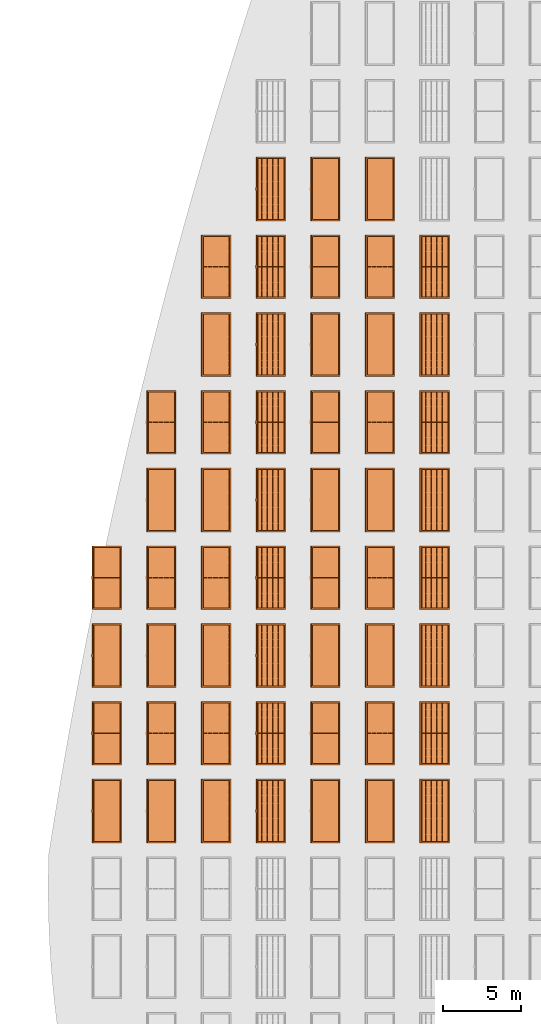
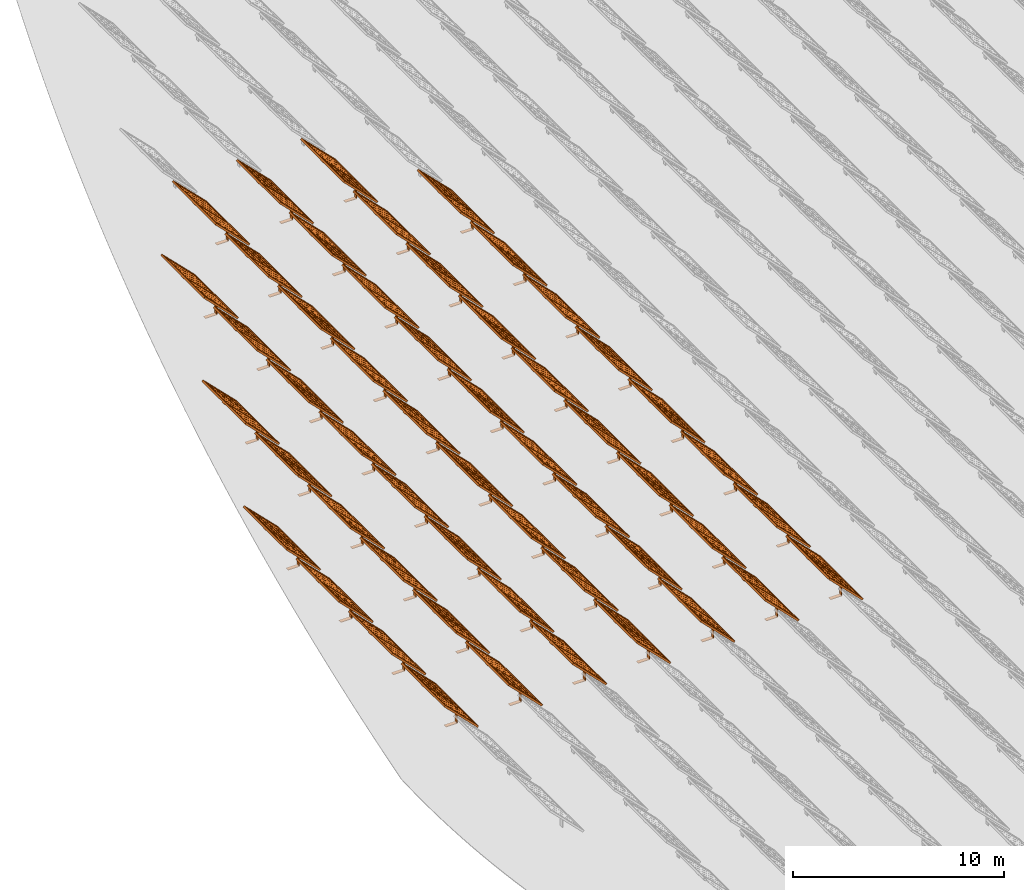
# One storey, part 21 of 39: 53 proxies.
"""IFC2X3 building model written with IfcOpenShell, lengths in millimetres."""

from ifc_helpers import new_model, entity, si_unit, converted_unit, derived_unit, direction, frame, frame_2d, origin, origin_2d_with_axis, place, context, subcontext, project, spatial, polyline, rectangle, outline, extrude, source, transform, mapped, material, material_list, element, save


model = new_model("IFC2X3")

# Units and contexts
model_context = context("Model", 3, precision=1e-06, world=origin(), true_north=direction((2.0, 6.12303176911189e-17, 1.0)))
context_of_model = context(None, 3, precision=1e-06, world=origin(), true_north=direction((2.0, 6.12303176911189e-17, 1.0)))
body_context = subcontext(model_context, "Body", "Model", "MODEL_VIEW")
ifc_project = project(units=[si_unit("LENGTHUNIT", "METRE", prefix="MILLI"), si_unit("AREAUNIT", "SQUARE_METRE", prefix="MILLI"), si_unit("VOLUMEUNIT", "CUBIC_METRE", prefix="MILLI"), converted_unit("PLANEANGLEUNIT", "DEGREE", entity("IfcRatioMeasure", 0.0174532925199433), si_unit("PLANEANGLEUNIT", "RADIAN"), dimensions=[0, 0, 0, 0, 0, 0, 0]), si_unit("MASSUNIT", "GRAM", prefix="KILO"), si_unit("TIMEUNIT", "SECOND"), si_unit("THERMODYNAMICTEMPERATUREUNIT", "KELVIN"), derived_unit("THERMALTRANSMITTANCEUNIT", [(si_unit("MASSUNIT", "GRAM", prefix="KILO"), 1), (si_unit("THERMODYNAMICTEMPERATUREUNIT", "KELVIN"), -1), (si_unit("TIMEUNIT", "SECOND"), -3)]), derived_unit("VOLUMETRICFLOWRATEUNIT", [(si_unit("LENGTHUNIT", "METRE"), 3), (si_unit("TIMEUNIT", "SECOND"), -1)])], contexts=[model_context, context_of_model])

# Site, building, storey
site_placement = place(None, origin())
site = spatial("IfcSite", under=ifc_project, at=site_placement, CompositionType="ELEMENT")
building_placement = place(site_placement, origin())
building = spatial("IfcBuilding", under=site, at=building_placement, CompositionType="ELEMENT")
storey_placement = place(building_placement, frame((0.0, 0.0, 4000.0)))
storey = spatial("IfcBuildingStorey", under=building, at=storey_placement, Name="Level 2", CompositionType="ELEMENT", Elevation=4000.0)

# Proxies
ifc_material_1 = material(Name="Stand-Steel")
ifc_material_2 = material(Name="Aluminium")
ifc_material_3 = material(Name="Glass")
ifc_material_list_1 = material_list([ifc_material_1, ifc_material_2, ifc_material_3])
shared_shape = source(origin(), body_context, "Body", "SweptSolid", [
    extrude(outline(polyline([(-629.526235435404, -220.0), (329.763117717702, -220.0), (329.763117717703, 410.0), (299.763117717703, 410.0), (299.763117717702, -190.0), (-629.526235435404, -190.0), (-629.526235435404, -220.0)])), frame((-190.00003127179, -100.0, 299.763117717707), z_axis=(0.0, 1.0, 0.0), x_axis=(0.0, 0.0, -1.0)), (0.0, 0.0, 1.0), 200.0),
    extrude(rectangle(XDim=20.0000000000001, YDim=200.0, at=frame_2d((0.0, -7.105427357601e-14), x_axis=(0.0, 1.0))), frame((-7.07109908365613, 0.0, 922.21828534124), z_axis=(-0.70710678118654, 0.0, 0.707106781186555), x_axis=(0.0, 1.0, 0.0)), (0.0, 0.0, 1.0), 2600.0),
    extrude(rectangle(XDim=24.9999999999997, YDim=24.9999999999999, at=frame_2d((2.87769807982841e-13, -9.50350909079134e-14), x_axis=(1.0, 0.0))), frame((-1449.56292018118, -1950.0, 2449.57494522722), z_axis=(0.0, 1.0, 0.0), x_axis=(-0.707106781186548, 0.0, -0.707106781186548)), (0.0, 0.0, 1.0), 3900.0),
    extrude(rectangle(XDim=24.9999999999999, YDim=25.0000000000001, at=origin_2d_with_axis()), frame((-1096.0095295879, -1950.0, 2096.02155463395), z_axis=(0.0, 1.0, 0.0), x_axis=(-0.707106781186542, 0.0, -0.707106781186553)), (0.0, 0.0, 1.0), 3900.0),
    extrude(rectangle(XDim=24.9999999999999, YDim=25.0000000000001, at=origin_2d_with_axis()), frame((-742.456138994631, -1950.0, 1742.46816404067), z_axis=(0.0, 1.0, 0.0), x_axis=(-0.707106781186542, 0.0, -0.707106781186553)), (0.0, 0.0, 1.0), 3900.0),
    extrude(rectangle(XDim=25.0, YDim=24.9999999999997, at=frame_2d((-7.19424519957101e-14, 1.19904086659517e-13), x_axis=(1.0, 0.0))), frame((-388.902748401358, -1950.0, 1388.9147734474), z_axis=(0.0, 1.0, 0.0), x_axis=(-0.707106781186545, 0.0, -0.70710678118655)), (0.0, 0.0, 1.0), 3900.0),
    extrude(rectangle(XDim=25.0000000000002, YDim=25.0, at=frame_2d((1.35891298214119e-13, 6.21724893790088e-15), x_axis=(0.0, 1.0))), frame((-35.3553703311048, 1500.0, 1035.35537033109), z_axis=(-0.707106781186544, 0.0, 0.707106781186551), x_axis=(0.0, 1.0, 0.0)), (0.0, 0.0, 1.0), 2440.0),
    extrude(rectangle(XDim=25.0000000000002, YDim=25.0, at=frame_2d((0.0, 1.77635683940025e-15), x_axis=(0.0, 1.0))), frame((-35.3553703311059, 1000.0, 1035.35537033109), z_axis=(-0.707106781186546, 0.0, 0.707106781186549), x_axis=(0.0, 1.0, 0.0)), (0.0, 0.0, 1.0), 2440.0),
    extrude(rectangle(XDim=25.0000000000002, YDim=25.0, at=frame_2d((0.0, 8.43769498715119e-14), x_axis=(0.0, 1.0))), frame((-26.5165355662756, 0.0, 1044.19420509593), z_axis=(-0.707106781186546, 0.0, 0.707106781186549), x_axis=(0.0, -1.0, 0.0)), (0.0, 0.0, 1.0), 2440.0),
    extrude(rectangle(XDim=25.0000000000002, YDim=25.0, at=frame_2d((0.0, 8.88178419700125e-16), x_axis=(0.0, 1.0))), frame((-35.3553703311065, 500.0, 1035.35537033109), z_axis=(-0.707106781186546, 0.0, 0.707106781186549), x_axis=(0.0, 1.0, 0.0)), (0.0, 0.0, 1.0), 2440.0),
    extrude(rectangle(XDim=25.0000000000002, YDim=25.0, at=frame_2d((0.0, 8.88178419700125e-16), x_axis=(0.0, 1.0))), frame((-35.3553703311086, -500.0, 1035.35537033109), z_axis=(-0.707106781186546, 0.0, 0.707106781186549), x_axis=(0.0, 1.0, 0.0)), (0.0, 0.0, 1.0), 2440.0),
    extrude(rectangle(XDim=25.0000000000002, YDim=25.0, at=frame_2d((0.0, 8.88178419700125e-16), x_axis=(0.0, 1.0))), frame((-35.3553703311095, -1000.0, 1035.35537033109), z_axis=(-0.707106781186546, 0.0, 0.707106781186549), x_axis=(0.0, 1.0, 0.0)), (0.0, 0.0, 1.0), 2440.0),
    extrude(rectangle(XDim=25.0000000000002, YDim=25.0, at=frame_2d((1.35891298214119e-13, 1.77635683940025e-15), x_axis=(0.0, 1.0))), frame((-35.3553703311107, -1500.0, 1035.35537033109), z_axis=(-0.707106781186546, 0.0, 0.707106781186549), x_axis=(0.0, 1.0, 0.0)), (0.0, 0.0, 1.0), 2440.0),
    extrude(rectangle(XDim=2400.0, YDim=11.9999999999994, at=frame_2d((-1.13686837721616e-13, 2.02948768901479e-13), x_axis=(1.0, 0.0))), frame((-883.883507754966, -1950.0, 1883.88350775495), z_axis=(0.0, 1.0, 0.0), x_axis=(0.707106781186546, 0.0, -0.707106781186549)), (0.0, 0.0, 1.0), 3900.0),
    extrude(outline(polyline([(-2050.0, -1300.0), (2050.0, -1300.0), (2050.0, 1300.0), (-2050.0, 1300.0), (-2050.0, -1300.0)]), holes=[polyline([(1950.0, -1200.0), (-1950.0, -1200.0), (-1950.0, 1200.0), (1950.0, 1200.0), (1950.0, -1200.0)])]), frame((-919.238846814293, 0.0, 1848.52816869563), z_axis=(0.707106781186554, 0.0, 0.707106781186541), x_axis=(0.0, 1.0, 0.0)), (0.0, 0.0, 1.0), 99.9999999999898),
])
proxy_1_placement = place(storey_placement, frame((-209095.328311831, 500144.680552409, 30.0)))
element("IfcBuildingElementProxy", 1, at=proxy_1_placement, inside=storey, material=ifc_material_list_1, Name="Solar Panel_4000X2500:Solar Panel_4000X2500", ObjectType="Solar Panel_4000X2500", CompositionType="ELEMENT", context=body_context, shape_type="MappedRepresentation", body=[
    mapped(shared_shape, transform((0.0, 0.0, 0.0), scale=1.0)),
])
ifc_material_list_2 = material_list([ifc_material_1, ifc_material_2, ifc_material_3])
proxy_2_placement = place(storey_placement, frame((-209095.328311831, 505144.680552409, 30.0)))
element("IfcBuildingElementProxy", 2, at=proxy_2_placement, inside=storey, material=ifc_material_list_2, Name="Solar Panel_4000X2500:Solar Panel_4000X2500", ObjectType="Solar Panel_4000X2500", CompositionType="ELEMENT", context=body_context, shape_type="MappedRepresentation", body=[
    mapped(shared_shape, transform((0.0, 0.0, 0.0), scale=1.0)),
])
ifc_material_list_3 = material_list([ifc_material_1, ifc_material_2, ifc_material_3])
proxy_3_placement = place(storey_placement, frame((-209095.328311831, 510144.680552409, 30.0)))
element("IfcBuildingElementProxy", 3, at=proxy_3_placement, inside=storey, material=ifc_material_list_3, Name="Solar Panel_4000X2500:Solar Panel_4000X2500", ObjectType="Solar Panel_4000X2500", CompositionType="ELEMENT", context=body_context, shape_type="MappedRepresentation", body=[
    mapped(shared_shape, transform((0.0, 0.0, 0.0), scale=1.0)),
])
ifc_material_list_4 = material_list([ifc_material_1, ifc_material_2, ifc_material_3])
proxy_4_placement = place(storey_placement, frame((-209095.328311831, 515144.680552409, 30.0)))
element("IfcBuildingElementProxy", 4, at=proxy_4_placement, inside=storey, material=ifc_material_list_4, Name="Solar Panel_4000X2500:Solar Panel_4000X2500", ObjectType="Solar Panel_4000X2500", CompositionType="ELEMENT", context=body_context, shape_type="MappedRepresentation", body=[
    mapped(shared_shape, transform((0.0, 0.0, 0.0), scale=1.0)),
])
ifc_material_list_5 = material_list([ifc_material_1, ifc_material_2, ifc_material_3])
proxy_5_placement = place(storey_placement, frame((-209095.328311831, 520144.680552409, 30.0)))
element("IfcBuildingElementProxy", 5, at=proxy_5_placement, inside=storey, material=ifc_material_list_5, Name="Solar Panel_4000X2500:Solar Panel_4000X2500", ObjectType="Solar Panel_4000X2500", CompositionType="ELEMENT", context=body_context, shape_type="MappedRepresentation", body=[
    mapped(shared_shape, transform((0.0, 0.0, 0.0), scale=1.0)),
])
ifc_material_list_6 = material_list([ifc_material_1, ifc_material_2, ifc_material_3])
proxy_6_placement = place(storey_placement, frame((-209095.328311831, 525144.680552409, 30.0)))
element("IfcBuildingElementProxy", 6, at=proxy_6_placement, inside=storey, material=ifc_material_list_6, Name="Solar Panel_4000X2500:Solar Panel_4000X2500", ObjectType="Solar Panel_4000X2500", CompositionType="ELEMENT", context=body_context, shape_type="MappedRepresentation", body=[
    mapped(shared_shape, transform((0.0, 0.0, 0.0), scale=1.0)),
])
ifc_material_list_7 = material_list([ifc_material_1, ifc_material_2, ifc_material_3])
proxy_7_placement = place(storey_placement, frame((-209095.328311831, 530144.680552409, 30.0)))
element("IfcBuildingElementProxy", 7, at=proxy_7_placement, inside=storey, material=ifc_material_list_7, Name="Solar Panel_4000X2500:Solar Panel_4000X2500", ObjectType="Solar Panel_4000X2500", CompositionType="ELEMENT", context=body_context, shape_type="MappedRepresentation", body=[
    mapped(shared_shape, transform((0.0, 0.0, 0.0), scale=1.0)),
])
ifc_material_list_8 = material_list([ifc_material_1, ifc_material_2, ifc_material_3])
proxy_8_placement = place(storey_placement, frame((-209095.328311831, 535144.680552409, 30.0)))
element("IfcBuildingElementProxy", 8, at=proxy_8_placement, inside=storey, material=ifc_material_list_8, Name="Solar Panel_4000X2500:Solar Panel_4000X2500", ObjectType="Solar Panel_4000X2500", CompositionType="ELEMENT", context=body_context, shape_type="MappedRepresentation", body=[
    mapped(shared_shape, transform((0.0, 0.0, 0.0), scale=1.0)),
])
ifc_material_list_9 = material_list([ifc_material_1, ifc_material_2, ifc_material_3])
proxy_9_placement = place(storey_placement, frame((-212610.328311831, 500144.680552409, 30.0)))
element("IfcBuildingElementProxy", 9, at=proxy_9_placement, inside=storey, material=ifc_material_list_9, Name="Solar Panel_4000X2500:Solar Panel_4000X2500", ObjectType="Solar Panel_4000X2500", CompositionType="ELEMENT", context=body_context, shape_type="MappedRepresentation", body=[
    mapped(shared_shape, transform((0.0, 0.0, 0.0), scale=1.0)),
])
ifc_material_list_10 = material_list([ifc_material_1, ifc_material_2, ifc_material_3])
proxy_10_placement = place(storey_placement, frame((-212610.328311831, 505144.680552409, 30.0)))
element("IfcBuildingElementProxy", 10, at=proxy_10_placement, inside=storey, material=ifc_material_list_10, Name="Solar Panel_4000X2500:Solar Panel_4000X2500", ObjectType="Solar Panel_4000X2500", CompositionType="ELEMENT", context=body_context, shape_type="MappedRepresentation", body=[
    mapped(shared_shape, transform((0.0, 0.0, 0.0), scale=1.0)),
])
ifc_material_list_11 = material_list([ifc_material_1, ifc_material_2, ifc_material_3])
proxy_11_placement = place(storey_placement, frame((-212610.328311831, 510144.680552409, 30.0)))
element("IfcBuildingElementProxy", 11, at=proxy_11_placement, inside=storey, material=ifc_material_list_11, Name="Solar Panel_4000X2500:Solar Panel_4000X2500", ObjectType="Solar Panel_4000X2500", CompositionType="ELEMENT", context=body_context, shape_type="MappedRepresentation", body=[
    mapped(shared_shape, transform((0.0, 0.0, 0.0), scale=1.0)),
])
ifc_material_list_12 = material_list([ifc_material_1, ifc_material_2, ifc_material_3])
proxy_12_placement = place(storey_placement, frame((-212610.328311831, 515144.680552409, 30.0)))
element("IfcBuildingElementProxy", 12, at=proxy_12_placement, inside=storey, material=ifc_material_list_12, Name="Solar Panel_4000X2500:Solar Panel_4000X2500", ObjectType="Solar Panel_4000X2500", CompositionType="ELEMENT", context=body_context, shape_type="MappedRepresentation", body=[
    mapped(shared_shape, transform((0.0, 0.0, 0.0), scale=1.0)),
])
ifc_material_list_13 = material_list([ifc_material_1, ifc_material_2, ifc_material_3])
proxy_13_placement = place(storey_placement, frame((-212610.328311831, 520144.680552409, 30.0)))
element("IfcBuildingElementProxy", 13, at=proxy_13_placement, inside=storey, material=ifc_material_list_13, Name="Solar Panel_4000X2500:Solar Panel_4000X2500", ObjectType="Solar Panel_4000X2500", CompositionType="ELEMENT", context=body_context, shape_type="MappedRepresentation", body=[
    mapped(shared_shape, transform((0.0, 0.0, 0.0), scale=1.0)),
])
ifc_material_list_14 = material_list([ifc_material_1, ifc_material_2, ifc_material_3])
proxy_14_placement = place(storey_placement, frame((-212610.328311831, 525144.680552409, 30.0)))
element("IfcBuildingElementProxy", 14, at=proxy_14_placement, inside=storey, material=ifc_material_list_14, Name="Solar Panel_4000X2500:Solar Panel_4000X2500", ObjectType="Solar Panel_4000X2500", CompositionType="ELEMENT", context=body_context, shape_type="MappedRepresentation", body=[
    mapped(shared_shape, transform((0.0, 0.0, 0.0), scale=1.0)),
])
ifc_material_list_15 = material_list([ifc_material_1, ifc_material_2, ifc_material_3])
proxy_15_placement = place(storey_placement, frame((-212610.328311831, 530144.680552409, 30.0)))
element("IfcBuildingElementProxy", 15, at=proxy_15_placement, inside=storey, material=ifc_material_list_15, Name="Solar Panel_4000X2500:Solar Panel_4000X2500", ObjectType="Solar Panel_4000X2500", CompositionType="ELEMENT", context=body_context, shape_type="MappedRepresentation", body=[
    mapped(shared_shape, transform((0.0, 0.0, 0.0), scale=1.0)),
])
ifc_material_list_16 = material_list([ifc_material_1, ifc_material_2, ifc_material_3])
proxy_16_placement = place(storey_placement, frame((-212610.328311831, 535144.680552409, 30.0)))
element("IfcBuildingElementProxy", 16, at=proxy_16_placement, inside=storey, material=ifc_material_list_16, Name="Solar Panel_4000X2500:Solar Panel_4000X2500", ObjectType="Solar Panel_4000X2500", CompositionType="ELEMENT", context=body_context, shape_type="MappedRepresentation", body=[
    mapped(shared_shape, transform((0.0, 0.0, 0.0), scale=1.0)),
])
ifc_material_list_17 = material_list([ifc_material_1, ifc_material_2, ifc_material_3])
proxy_17_placement = place(storey_placement, frame((-212610.328311831, 540144.680552409, 30.0)))
element("IfcBuildingElementProxy", 17, at=proxy_17_placement, inside=storey, material=ifc_material_list_17, Name="Solar Panel_4000X2500:Solar Panel_4000X2500", ObjectType="Solar Panel_4000X2500", CompositionType="ELEMENT", context=body_context, shape_type="MappedRepresentation", body=[
    mapped(shared_shape, transform((0.0, 0.0, 0.0), scale=1.0)),
])
ifc_material_list_18 = material_list([ifc_material_1, ifc_material_2, ifc_material_3])
proxy_18_placement = place(storey_placement, frame((-216125.328311831, 500144.680552409, 30.0)))
element("IfcBuildingElementProxy", 18, at=proxy_18_placement, inside=storey, material=ifc_material_list_18, Name="Solar Panel_4000X2500:Solar Panel_4000X2500", ObjectType="Solar Panel_4000X2500", CompositionType="ELEMENT", context=body_context, shape_type="MappedRepresentation", body=[
    mapped(shared_shape, transform((0.0, 0.0, 0.0), scale=1.0)),
])
ifc_material_list_19 = material_list([ifc_material_1, ifc_material_2, ifc_material_3])
proxy_19_placement = place(storey_placement, frame((-216125.328311831, 505144.680552409, 30.0)))
element("IfcBuildingElementProxy", 19, at=proxy_19_placement, inside=storey, material=ifc_material_list_19, Name="Solar Panel_4000X2500:Solar Panel_4000X2500", ObjectType="Solar Panel_4000X2500", CompositionType="ELEMENT", context=body_context, shape_type="MappedRepresentation", body=[
    mapped(shared_shape, transform((0.0, 0.0, 0.0), scale=1.0)),
])
ifc_material_list_20 = material_list([ifc_material_1, ifc_material_2, ifc_material_3])
proxy_20_placement = place(storey_placement, frame((-216125.328311831, 510144.680552409, 30.0)))
element("IfcBuildingElementProxy", 20, at=proxy_20_placement, inside=storey, material=ifc_material_list_20, Name="Solar Panel_4000X2500:Solar Panel_4000X2500", ObjectType="Solar Panel_4000X2500", CompositionType="ELEMENT", context=body_context, shape_type="MappedRepresentation", body=[
    mapped(shared_shape, transform((0.0, 0.0, 0.0), scale=1.0)),
])
ifc_material_list_21 = material_list([ifc_material_1, ifc_material_2, ifc_material_3])
proxy_21_placement = place(storey_placement, frame((-216125.328311831, 515144.680552409, 30.0)))
element("IfcBuildingElementProxy", 21, at=proxy_21_placement, inside=storey, material=ifc_material_list_21, Name="Solar Panel_4000X2500:Solar Panel_4000X2500", ObjectType="Solar Panel_4000X2500", CompositionType="ELEMENT", context=body_context, shape_type="MappedRepresentation", body=[
    mapped(shared_shape, transform((0.0, 0.0, 0.0), scale=1.0)),
])
ifc_material_list_22 = material_list([ifc_material_1, ifc_material_2, ifc_material_3])
proxy_22_placement = place(storey_placement, frame((-216125.328311831, 520144.680552409, 30.0)))
element("IfcBuildingElementProxy", 22, at=proxy_22_placement, inside=storey, material=ifc_material_list_22, Name="Solar Panel_4000X2500:Solar Panel_4000X2500", ObjectType="Solar Panel_4000X2500", CompositionType="ELEMENT", context=body_context, shape_type="MappedRepresentation", body=[
    mapped(shared_shape, transform((0.0, 0.0, 0.0), scale=1.0)),
])
ifc_material_list_23 = material_list([ifc_material_1, ifc_material_2, ifc_material_3])
proxy_23_placement = place(storey_placement, frame((-216125.328311831, 525144.680552409, 30.0)))
element("IfcBuildingElementProxy", 23, at=proxy_23_placement, inside=storey, material=ifc_material_list_23, Name="Solar Panel_4000X2500:Solar Panel_4000X2500", ObjectType="Solar Panel_4000X2500", CompositionType="ELEMENT", context=body_context, shape_type="MappedRepresentation", body=[
    mapped(shared_shape, transform((0.0, 0.0, 0.0), scale=1.0)),
])
ifc_material_list_24 = material_list([ifc_material_1, ifc_material_2, ifc_material_3])
proxy_24_placement = place(storey_placement, frame((-216125.328311831, 530144.680552409, 30.0)))
element("IfcBuildingElementProxy", 24, at=proxy_24_placement, inside=storey, material=ifc_material_list_24, Name="Solar Panel_4000X2500:Solar Panel_4000X2500", ObjectType="Solar Panel_4000X2500", CompositionType="ELEMENT", context=body_context, shape_type="MappedRepresentation", body=[
    mapped(shared_shape, transform((0.0, 0.0, 0.0), scale=1.0)),
])
ifc_material_list_25 = material_list([ifc_material_1, ifc_material_2, ifc_material_3])
proxy_25_placement = place(storey_placement, frame((-216125.328311831, 535144.680552409, 30.0)))
element("IfcBuildingElementProxy", 25, at=proxy_25_placement, inside=storey, material=ifc_material_list_25, Name="Solar Panel_4000X2500:Solar Panel_4000X2500", ObjectType="Solar Panel_4000X2500", CompositionType="ELEMENT", context=body_context, shape_type="MappedRepresentation", body=[
    mapped(shared_shape, transform((0.0, 0.0, 0.0), scale=1.0)),
])
ifc_material_list_26 = material_list([ifc_material_1, ifc_material_2, ifc_material_3])
proxy_26_placement = place(storey_placement, frame((-216125.328311831, 540144.680552409, 30.0)))
element("IfcBuildingElementProxy", 26, at=proxy_26_placement, inside=storey, material=ifc_material_list_26, Name="Solar Panel_4000X2500:Solar Panel_4000X2500", ObjectType="Solar Panel_4000X2500", CompositionType="ELEMENT", context=body_context, shape_type="MappedRepresentation", body=[
    mapped(shared_shape, transform((0.0, 0.0, 0.0), scale=1.0)),
])
ifc_material_list_27 = material_list([ifc_material_1, ifc_material_2, ifc_material_3])
proxy_27_placement = place(storey_placement, frame((-219640.328311831, 500144.680552409, 30.0)))
element("IfcBuildingElementProxy", 27, at=proxy_27_placement, inside=storey, material=ifc_material_list_27, Name="Solar Panel_4000X2500:Solar Panel_4000X2500", ObjectType="Solar Panel_4000X2500", CompositionType="ELEMENT", context=body_context, shape_type="MappedRepresentation", body=[
    mapped(shared_shape, transform((0.0, 0.0, 0.0), scale=1.0)),
])
ifc_material_list_28 = material_list([ifc_material_1, ifc_material_2, ifc_material_3])
proxy_28_placement = place(storey_placement, frame((-219640.328311831, 505144.680552409, 30.0)))
element("IfcBuildingElementProxy", 28, at=proxy_28_placement, inside=storey, material=ifc_material_list_28, Name="Solar Panel_4000X2500:Solar Panel_4000X2500", ObjectType="Solar Panel_4000X2500", CompositionType="ELEMENT", context=body_context, shape_type="MappedRepresentation", body=[
    mapped(shared_shape, transform((0.0, 0.0, 0.0), scale=1.0)),
])
ifc_material_list_29 = material_list([ifc_material_1, ifc_material_2, ifc_material_3])
proxy_29_placement = place(storey_placement, frame((-219640.328311831, 510144.680552409, 30.0)))
element("IfcBuildingElementProxy", 29, at=proxy_29_placement, inside=storey, material=ifc_material_list_29, Name="Solar Panel_4000X2500:Solar Panel_4000X2500", ObjectType="Solar Panel_4000X2500", CompositionType="ELEMENT", context=body_context, shape_type="MappedRepresentation", body=[
    mapped(shared_shape, transform((0.0, 0.0, 0.0), scale=1.0)),
])
ifc_material_list_30 = material_list([ifc_material_1, ifc_material_2, ifc_material_3])
proxy_30_placement = place(storey_placement, frame((-219640.328311831, 515144.680552409, 30.0)))
element("IfcBuildingElementProxy", 30, at=proxy_30_placement, inside=storey, material=ifc_material_list_30, Name="Solar Panel_4000X2500:Solar Panel_4000X2500", ObjectType="Solar Panel_4000X2500", CompositionType="ELEMENT", context=body_context, shape_type="MappedRepresentation", body=[
    mapped(shared_shape, transform((0.0, 0.0, 0.0), scale=1.0)),
])
ifc_material_list_31 = material_list([ifc_material_1, ifc_material_2, ifc_material_3])
proxy_31_placement = place(storey_placement, frame((-219640.328311831, 520144.680552409, 30.0)))
element("IfcBuildingElementProxy", 31, at=proxy_31_placement, inside=storey, material=ifc_material_list_31, Name="Solar Panel_4000X2500:Solar Panel_4000X2500", ObjectType="Solar Panel_4000X2500", CompositionType="ELEMENT", context=body_context, shape_type="MappedRepresentation", body=[
    mapped(shared_shape, transform((0.0, 0.0, 0.0), scale=1.0)),
])
ifc_material_list_32 = material_list([ifc_material_1, ifc_material_2, ifc_material_3])
proxy_32_placement = place(storey_placement, frame((-219640.328311831, 525144.680552409, 30.0)))
element("IfcBuildingElementProxy", 32, at=proxy_32_placement, inside=storey, material=ifc_material_list_32, Name="Solar Panel_4000X2500:Solar Panel_4000X2500", ObjectType="Solar Panel_4000X2500", CompositionType="ELEMENT", context=body_context, shape_type="MappedRepresentation", body=[
    mapped(shared_shape, transform((0.0, 0.0, 0.0), scale=1.0)),
])
ifc_material_list_33 = material_list([ifc_material_1, ifc_material_2, ifc_material_3])
proxy_33_placement = place(storey_placement, frame((-219640.328311831, 530144.680552409, 30.0)))
element("IfcBuildingElementProxy", 33, at=proxy_33_placement, inside=storey, material=ifc_material_list_33, Name="Solar Panel_4000X2500:Solar Panel_4000X2500", ObjectType="Solar Panel_4000X2500", CompositionType="ELEMENT", context=body_context, shape_type="MappedRepresentation", body=[
    mapped(shared_shape, transform((0.0, 0.0, 0.0), scale=1.0)),
])
ifc_material_list_34 = material_list([ifc_material_1, ifc_material_2, ifc_material_3])
proxy_34_placement = place(storey_placement, frame((-219640.328311831, 535144.680552409, 30.0)))
element("IfcBuildingElementProxy", 34, at=proxy_34_placement, inside=storey, material=ifc_material_list_34, Name="Solar Panel_4000X2500:Solar Panel_4000X2500", ObjectType="Solar Panel_4000X2500", CompositionType="ELEMENT", context=body_context, shape_type="MappedRepresentation", body=[
    mapped(shared_shape, transform((0.0, 0.0, 0.0), scale=1.0)),
])
ifc_material_list_35 = material_list([ifc_material_1, ifc_material_2, ifc_material_3])
proxy_35_placement = place(storey_placement, frame((-219640.328311831, 540144.680552409, 30.0)))
element("IfcBuildingElementProxy", 35, at=proxy_35_placement, inside=storey, material=ifc_material_list_35, Name="Solar Panel_4000X2500:Solar Panel_4000X2500", ObjectType="Solar Panel_4000X2500", CompositionType="ELEMENT", context=body_context, shape_type="MappedRepresentation", body=[
    mapped(shared_shape, transform((0.0, 0.0, 0.0), scale=1.0)),
])
ifc_material_list_36 = material_list([ifc_material_1, ifc_material_2, ifc_material_3])
proxy_36_placement = place(storey_placement, frame((-223155.328311831, 500144.680552409, 30.0)))
element("IfcBuildingElementProxy", 36, at=proxy_36_placement, inside=storey, material=ifc_material_list_36, Name="Solar Panel_4000X2500:Solar Panel_4000X2500", ObjectType="Solar Panel_4000X2500", CompositionType="ELEMENT", context=body_context, shape_type="MappedRepresentation", body=[
    mapped(shared_shape, transform((0.0, 0.0, 0.0), scale=1.0)),
])
ifc_material_list_37 = material_list([ifc_material_1, ifc_material_2, ifc_material_3])
proxy_37_placement = place(storey_placement, frame((-223155.328311831, 505144.680552409, 30.0)))
element("IfcBuildingElementProxy", 37, at=proxy_37_placement, inside=storey, material=ifc_material_list_37, Name="Solar Panel_4000X2500:Solar Panel_4000X2500", ObjectType="Solar Panel_4000X2500", CompositionType="ELEMENT", context=body_context, shape_type="MappedRepresentation", body=[
    mapped(shared_shape, transform((0.0, 0.0, 0.0), scale=1.0)),
])
ifc_material_list_38 = material_list([ifc_material_1, ifc_material_2, ifc_material_3])
proxy_38_placement = place(storey_placement, frame((-223155.328311831, 510144.680552409, 30.0)))
element("IfcBuildingElementProxy", 38, at=proxy_38_placement, inside=storey, material=ifc_material_list_38, Name="Solar Panel_4000X2500:Solar Panel_4000X2500", ObjectType="Solar Panel_4000X2500", CompositionType="ELEMENT", context=body_context, shape_type="MappedRepresentation", body=[
    mapped(shared_shape, transform((0.0, 0.0, 0.0), scale=1.0)),
])
ifc_material_list_39 = material_list([ifc_material_1, ifc_material_2, ifc_material_3])
proxy_39_placement = place(storey_placement, frame((-223155.328311831, 515144.680552409, 30.0)))
element("IfcBuildingElementProxy", 39, at=proxy_39_placement, inside=storey, material=ifc_material_list_39, Name="Solar Panel_4000X2500:Solar Panel_4000X2500", ObjectType="Solar Panel_4000X2500", CompositionType="ELEMENT", context=body_context, shape_type="MappedRepresentation", body=[
    mapped(shared_shape, transform((0.0, 0.0, 0.0), scale=1.0)),
])
ifc_material_list_40 = material_list([ifc_material_1, ifc_material_2, ifc_material_3])
proxy_40_placement = place(storey_placement, frame((-223155.328311831, 520144.680552409, 30.0)))
element("IfcBuildingElementProxy", 40, at=proxy_40_placement, inside=storey, material=ifc_material_list_40, Name="Solar Panel_4000X2500:Solar Panel_4000X2500", ObjectType="Solar Panel_4000X2500", CompositionType="ELEMENT", context=body_context, shape_type="MappedRepresentation", body=[
    mapped(shared_shape, transform((0.0, 0.0, 0.0), scale=1.0)),
])
ifc_material_list_41 = material_list([ifc_material_1, ifc_material_2, ifc_material_3])
proxy_41_placement = place(storey_placement, frame((-223155.328311831, 525144.680552409, 30.0)))
element("IfcBuildingElementProxy", 41, at=proxy_41_placement, inside=storey, material=ifc_material_list_41, Name="Solar Panel_4000X2500:Solar Panel_4000X2500", ObjectType="Solar Panel_4000X2500", CompositionType="ELEMENT", context=body_context, shape_type="MappedRepresentation", body=[
    mapped(shared_shape, transform((0.0, 0.0, 0.0), scale=1.0)),
])
ifc_material_list_42 = material_list([ifc_material_1, ifc_material_2, ifc_material_3])
proxy_42_placement = place(storey_placement, frame((-223155.328311831, 530144.680552409, 30.0)))
element("IfcBuildingElementProxy", 42, at=proxy_42_placement, inside=storey, material=ifc_material_list_42, Name="Solar Panel_4000X2500:Solar Panel_4000X2500", ObjectType="Solar Panel_4000X2500", CompositionType="ELEMENT", context=body_context, shape_type="MappedRepresentation", body=[
    mapped(shared_shape, transform((0.0, 0.0, 0.0), scale=1.0)),
])
ifc_material_list_43 = material_list([ifc_material_1, ifc_material_2, ifc_material_3])
proxy_43_placement = place(storey_placement, frame((-223155.328311831, 535144.680552409, 30.0)))
element("IfcBuildingElementProxy", 43, at=proxy_43_placement, inside=storey, material=ifc_material_list_43, Name="Solar Panel_4000X2500:Solar Panel_4000X2500", ObjectType="Solar Panel_4000X2500", CompositionType="ELEMENT", context=body_context, shape_type="MappedRepresentation", body=[
    mapped(shared_shape, transform((0.0, 0.0, 0.0), scale=1.0)),
])
ifc_material_list_44 = material_list([ifc_material_1, ifc_material_2, ifc_material_3])
proxy_44_placement = place(storey_placement, frame((-226670.328311831, 500144.680552409, 30.0)))
element("IfcBuildingElementProxy", 44, at=proxy_44_placement, inside=storey, material=ifc_material_list_44, Name="Solar Panel_4000X2500:Solar Panel_4000X2500", ObjectType="Solar Panel_4000X2500", CompositionType="ELEMENT", context=body_context, shape_type="MappedRepresentation", body=[
    mapped(shared_shape, transform((0.0, 0.0, 0.0), scale=1.0)),
])
ifc_material_list_45 = material_list([ifc_material_1, ifc_material_2, ifc_material_3])
proxy_45_placement = place(storey_placement, frame((-226670.328311831, 505144.680552409, 30.0)))
element("IfcBuildingElementProxy", 45, at=proxy_45_placement, inside=storey, material=ifc_material_list_45, Name="Solar Panel_4000X2500:Solar Panel_4000X2500", ObjectType="Solar Panel_4000X2500", CompositionType="ELEMENT", context=body_context, shape_type="MappedRepresentation", body=[
    mapped(shared_shape, transform((0.0, 0.0, 0.0), scale=1.0)),
])
ifc_material_list_46 = material_list([ifc_material_1, ifc_material_2, ifc_material_3])
proxy_46_placement = place(storey_placement, frame((-226670.328311831, 510144.680552409, 30.0)))
element("IfcBuildingElementProxy", 46, at=proxy_46_placement, inside=storey, material=ifc_material_list_46, Name="Solar Panel_4000X2500:Solar Panel_4000X2500", ObjectType="Solar Panel_4000X2500", CompositionType="ELEMENT", context=body_context, shape_type="MappedRepresentation", body=[
    mapped(shared_shape, transform((0.0, 0.0, 0.0), scale=1.0)),
])
ifc_material_list_47 = material_list([ifc_material_1, ifc_material_2, ifc_material_3])
proxy_47_placement = place(storey_placement, frame((-226670.328311831, 515144.680552409, 30.0)))
element("IfcBuildingElementProxy", 47, at=proxy_47_placement, inside=storey, material=ifc_material_list_47, Name="Solar Panel_4000X2500:Solar Panel_4000X2500", ObjectType="Solar Panel_4000X2500", CompositionType="ELEMENT", context=body_context, shape_type="MappedRepresentation", body=[
    mapped(shared_shape, transform((0.0, 0.0, 0.0), scale=1.0)),
])
ifc_material_list_48 = material_list([ifc_material_1, ifc_material_2, ifc_material_3])
proxy_48_placement = place(storey_placement, frame((-226670.328311831, 520144.680552409, 30.0)))
element("IfcBuildingElementProxy", 48, at=proxy_48_placement, inside=storey, material=ifc_material_list_48, Name="Solar Panel_4000X2500:Solar Panel_4000X2500", ObjectType="Solar Panel_4000X2500", CompositionType="ELEMENT", context=body_context, shape_type="MappedRepresentation", body=[
    mapped(shared_shape, transform((0.0, 0.0, 0.0), scale=1.0)),
])
ifc_material_list_49 = material_list([ifc_material_1, ifc_material_2, ifc_material_3])
proxy_49_placement = place(storey_placement, frame((-226670.328311831, 525144.680552409, 30.0)))
element("IfcBuildingElementProxy", 49, at=proxy_49_placement, inside=storey, material=ifc_material_list_49, Name="Solar Panel_4000X2500:Solar Panel_4000X2500", ObjectType="Solar Panel_4000X2500", CompositionType="ELEMENT", context=body_context, shape_type="MappedRepresentation", body=[
    mapped(shared_shape, transform((0.0, 0.0, 0.0), scale=1.0)),
])
ifc_material_list_50 = material_list([ifc_material_1, ifc_material_2, ifc_material_3])
proxy_50_placement = place(storey_placement, frame((-230185.328311831, 500144.680552409, 30.0)))
element("IfcBuildingElementProxy", 50, at=proxy_50_placement, inside=storey, material=ifc_material_list_50, Name="Solar Panel_4000X2500:Solar Panel_4000X2500", ObjectType="Solar Panel_4000X2500", CompositionType="ELEMENT", context=body_context, shape_type="MappedRepresentation", body=[
    mapped(shared_shape, transform((0.0, 0.0, 0.0), scale=1.0)),
])
ifc_material_list_51 = material_list([ifc_material_1, ifc_material_2, ifc_material_3])
proxy_51_placement = place(storey_placement, frame((-230185.328311831, 505144.680552409, 30.0)))
element("IfcBuildingElementProxy", 51, at=proxy_51_placement, inside=storey, material=ifc_material_list_51, Name="Solar Panel_4000X2500:Solar Panel_4000X2500", ObjectType="Solar Panel_4000X2500", CompositionType="ELEMENT", context=body_context, shape_type="MappedRepresentation", body=[
    mapped(shared_shape, transform((0.0, 0.0, 0.0), scale=1.0)),
])
ifc_material_list_52 = material_list([ifc_material_1, ifc_material_2, ifc_material_3])
proxy_52_placement = place(storey_placement, frame((-230185.328311831, 510144.680552409, 30.0)))
element("IfcBuildingElementProxy", 52, at=proxy_52_placement, inside=storey, material=ifc_material_list_52, Name="Solar Panel_4000X2500:Solar Panel_4000X2500", ObjectType="Solar Panel_4000X2500", CompositionType="ELEMENT", context=body_context, shape_type="MappedRepresentation", body=[
    mapped(shared_shape, transform((0.0, 0.0, 0.0), scale=1.0)),
])
ifc_material_list_53 = material_list([ifc_material_1, ifc_material_2, ifc_material_3])
proxy_53_placement = place(storey_placement, frame((-230185.328311831, 515144.680552409, 30.0)))
element("IfcBuildingElementProxy", 53, at=proxy_53_placement, inside=storey, material=ifc_material_list_53, Name="Solar Panel_4000X2500:Solar Panel_4000X2500", ObjectType="Solar Panel_4000X2500", CompositionType="ELEMENT", context=body_context, shape_type="MappedRepresentation", body=[
    mapped(shared_shape, transform((0.0, 0.0, 0.0), scale=1.0)),
])

save(model, "model.ifc")
